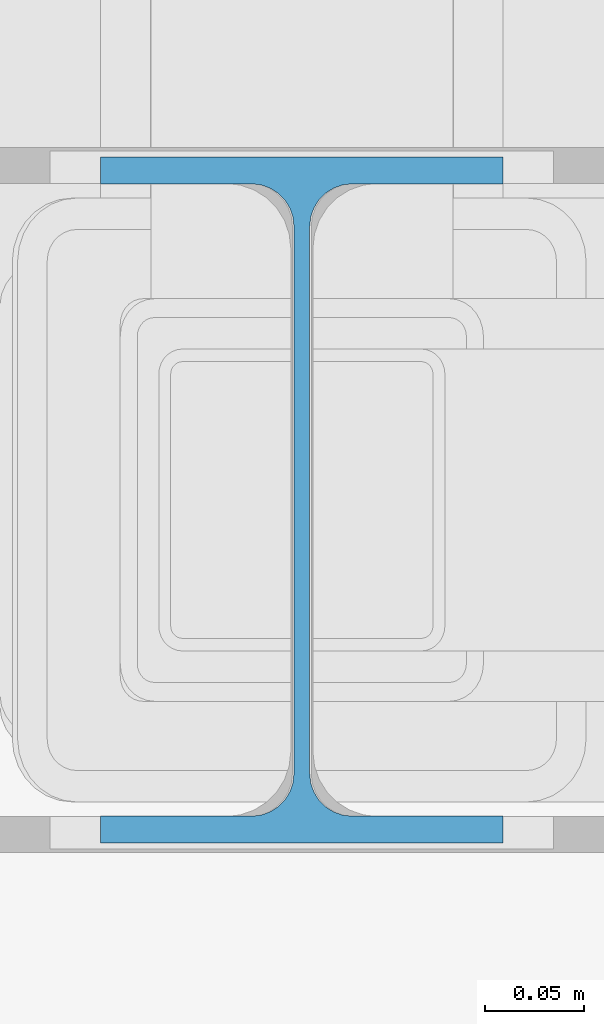
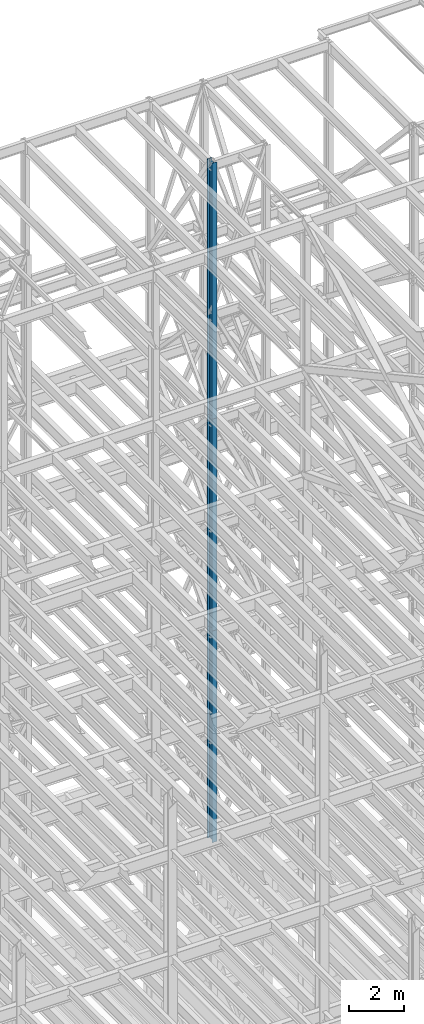
# One storey, part 102 of 150: 3 columns.
"""IFC2X3 building model written with IfcOpenShell, lengths in millimetres."""

from ifc_helpers import new_model, si_unit, frame, origin_with_axes, origin_2d_with_axis, place, context, subcontext, project, spatial, i_section, extrude, material, type_object, element, save


model = new_model("IFC2X3")

# Units and contexts
model_context = context("Model", 3, precision=1e-05, world=origin_with_axes())
body_context = subcontext(model_context, "Body", "Model", "MODEL_VIEW")
ifc_project = project(units=[si_unit("LENGTHUNIT", "METRE", prefix="MILLI"), si_unit("AREAUNIT", "SQUARE_METRE"), si_unit("VOLUMEUNIT", "CUBIC_METRE"), si_unit("MASSUNIT", "GRAM", prefix="KILO"), si_unit("TIMEUNIT", "SECOND"), si_unit("PLANEANGLEUNIT", "RADIAN"), si_unit("SOLIDANGLEUNIT", "STERADIAN"), si_unit("THERMODYNAMICTEMPERATUREUNIT", "DEGREE_CELSIUS"), si_unit("LUMINOUSINTENSITYUNIT", "LUMEN")], contexts=[model_context])

# Site, building, storey
site_placement = place(None, origin_with_axes())
site = spatial("IfcSite", under=ifc_project, at=site_placement, CompositionType="ELEMENT")
building_placement = place(site_placement, origin_with_axes())
building = spatial("IfcBuilding", under=site, at=building_placement, Name="Undefined", CompositionType="ELEMENT")
storey_placement = place(building_placement, origin_with_axes())
storey = spatial("IfcBuildingStorey", under=building, at=storey_placement, Name="Undefined", CompositionType="ELEMENT", Elevation=0.0)

# Columns
ifc_material = material(Name="STEEL/A992")
column_type = type_object("IfcColumnType", Name="W14X43", PredefinedType="NOTDEFINED")
column_placement = place(storey_placement, frame((74663.3, 27355.8, 54483.0), z_axis=(0.0, 0.0, 1.0), x_axis=(1.0, 0.0, 0.0)))
element("IfcColumn", 1, at=column_placement, inside=storey, type_object=column_type, material=ifc_material, Name="COLUMN", ObjectType="W14X43", context=body_context, shape_type="SweptSolid", body=[
    extrude(i_section(OverallWidth=203.2, OverallDepth=346.075, WebThickness=7.9375, FlangeThickness=13.462, FilletRadius=21.4629, at=origin_2d_with_axis()), frame((0.0, 0.0, 11429.998857), z_axis=(0.0, 0.0, -1.0), x_axis=(-1.0, 0.0, 0.0)), (0.0, 0.0, 1.0), 11429.998857),
])
for number, where, z_axis, x_axis, name in (
    (2, (74663.3, 27355.8, 45034.2), (0.0, 0.0, 1.0), (1.0, 0.0, 0.0), "COLUMN"),
    (3, (74663.3, 27355.8, 35585.4), (0.0, 0.0, 1.0), (1.0, 0.0, 0.0), "COLUMN"),
):
    element("IfcColumn", number, at=place(storey_placement, frame(where, z_axis=z_axis, x_axis=x_axis)), inside=storey, type_object=column_type, material=ifc_material, Name=name, ObjectType="W14X43", context=body_context, shape_type="SweptSolid", body=[
        extrude(i_section(OverallWidth=203.2, OverallDepth=346.075, WebThickness=7.9375, FlangeThickness=13.462, FilletRadius=21.4629, at=origin_2d_with_axis()), frame((0.0, 0.0, 9448.8), z_axis=(0.0, 0.0, -1.0), x_axis=(-1.0, 0.0, 0.0)), (0.0, 0.0, 1.0), 9448.8),
    ])

save(model, "model.ifc")
